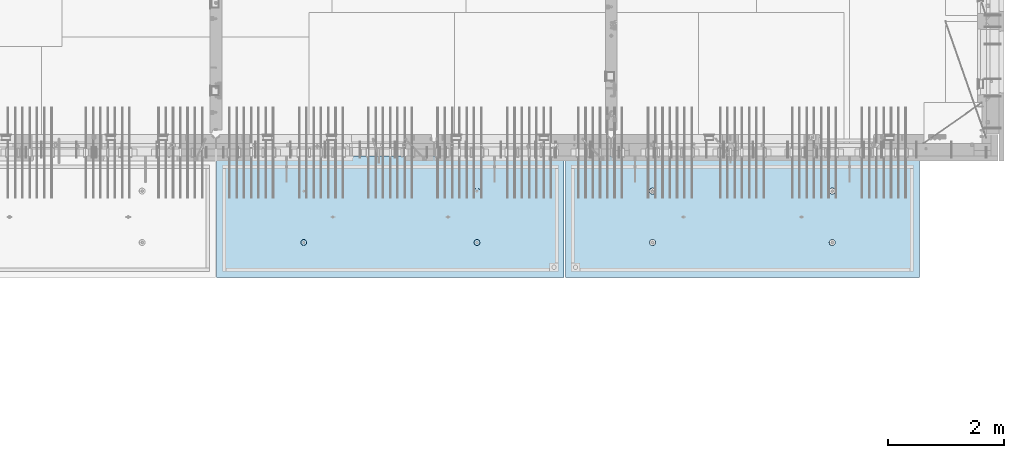
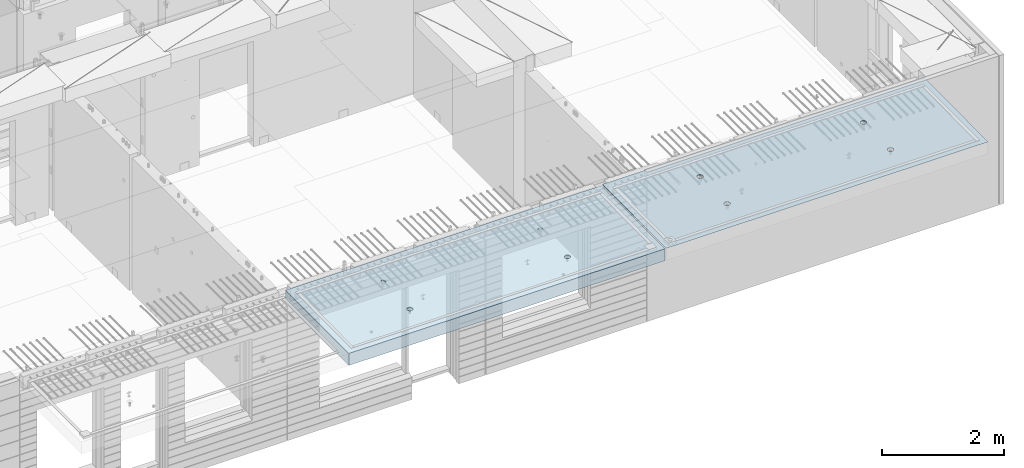
# One storey, part 203 of 350: 2 slabs, 2 elements without a shape of their own.
"""IFC2X3 building model written with IfcOpenShell, lengths in millimetres."""

from ifc_helpers import new_model, si_unit, frame, origin_with_axes, place, context, subcontext, project, spatial, faceted_brep, material, type_object, element, aggregate, save


model = new_model("IFC2X3")

# Units and contexts
model_context = context("Model", 3, precision=1e-05, world=origin_with_axes())
body_context = subcontext(model_context, "Body", "Model", "MODEL_VIEW")
ifc_project = project(units=[si_unit("LENGTHUNIT", "METRE", prefix="MILLI"), si_unit("AREAUNIT", "SQUARE_METRE"), si_unit("VOLUMEUNIT", "CUBIC_METRE"), si_unit("MASSUNIT", "GRAM", prefix="KILO"), si_unit("TIMEUNIT", "SECOND"), si_unit("PLANEANGLEUNIT", "RADIAN"), si_unit("SOLIDANGLEUNIT", "STERADIAN"), si_unit("THERMODYNAMICTEMPERATUREUNIT", "DEGREE_CELSIUS"), si_unit("LUMINOUSINTENSITYUNIT", "LUMEN")], contexts=[model_context])

# Site, building, storey
site_placement = place(None, origin_with_axes())
site = spatial("IfcSite", under=ifc_project, at=site_placement, CompositionType="ELEMENT")
building_placement = place(site_placement, origin_with_axes())
building = spatial("IfcBuilding", under=site, at=building_placement, CompositionType="ELEMENT")
storey_placement = place(building_placement, origin_with_axes())
storey = spatial("IfcBuildingStorey", under=building, at=storey_placement, Name="2", CompositionType="ELEMENT", Elevation=0.0)

# Assembly, slab
assembly_1_placement = place(storey_placement, origin_with_axes())
assembly_1 = element("IfcElementAssembly", 1, at=assembly_1_placement, inside=storey, AssemblyPlace="NOTDEFINED", PredefinedType="REINFORCEMENT_UNIT")
ifc_material = material(Name="CONCRETE/C35/45")
slab_type_1 = type_object("IfcSlabType", PredefinedType="NOTDEFINED")
slab_1_placement = place(assembly_1_placement, frame((33909.9998568133, 7629.99655735226, 87720.0), z_axis=(-1.11800000013248e-06, -0.999999999999375, 0.0), x_axis=(-0.999999999999093, 1.34699999998405e-06, 0.0)))
slab_1 = element("IfcSlab", 2, at=slab_1_placement, type_object=slab_type_1, material=ifc_material, PredefinedType="FLOOR", context=body_context, shape_type="Brep", body=[
    faceted_brep([(4540.5429407651, 4.39872694581572, 1501.06992058926), (4541.14829635528, 10.0, 1500.87322939105), (4548.44394652849, 10.0, 1515.19178906455), (4547.94177529477, 4.5376880098047, 1515.55663695519), (4559.80720044041, 10.0, 1526.55506865745), (4559.44971344555, 4.64790814399021, 1527.04710612474), (4574.1257436257, 10.0, 1533.85075119058), (4573.94028523447, 4.71864591048507, 1534.42153123348), (4589.99797731422, 10.0, 1536.36468442559), (4589.99797663917, 4.74301553473924, 1536.96206902392), (4605.87021668419, 10.0, 1533.85078706184), (4606.05567377324, 4.71864625823218, 1534.42156748629), (4620.18877635769, 10.0, 1526.55513688863), (4620.54626219634, 4.64790880566579, 1527.04717510301), (4631.55205595059, 10.0, 1515.19188297671), (4632.05422627598, 4.53768892097287, 1515.5567319414), (4638.84773848372, 10.0, 1500.87333979142), (4639.45309351355, 4.39872801757883, 1501.0700323201), (4641.36167171873, 10.0, 1485.0011061029), (4642.01569559209, 4.24458991442225, 1485.00110684195), (4638.84777435497, 10.0, 1469.12886673293), (4639.48645790269, 4.09034788147255, 1468.92134666652), (4631.55212418177, 10.0, 1454.81030705943), (4632.10822132771, 3.95111487063696, 1454.40627979329), (4620.18887026985, 10.0, 1443.44702746653), (4620.60028327593, 3.84055859092041, 1442.88076738872), (4605.87032708456, 10.0, 1436.1513449334), (4606.0891136727, 3.76954887632746, 1435.47799164192), (4589.99809339604, 10.0, 1433.63741169839), (4589.99809419923, 3.74507537655882, 1432.92662480936), (4574.12585402606, 10.0, 1436.15130906214), (4573.90706894744, 3.76954852712515, 1435.47795523847), (4559.80729435257, 10.0, 1443.44695923535), (4559.39588258188, 3.84055792690197, 1442.8806981667), (4548.44401475967, 10.0, 1454.81021314727), (4547.88791844284, 3.95111395715503, 1454.40618456334), (4541.14833222653, 10.0, 1469.12875633256), (4540.50964903182, 4.09034680826881, 1468.92123478504), (4538.63439899152, 10.0, 1485.00099002108), (4537.98037499001, 4.24458878673613, 1485.00098928203), (0.0, 10.0, 0.0), (0.0, -10.0, 0.0), (0.000819232023786753, 10.0, 2085.00366210937), (6090.0, 10.0, 1.39971234602854e-09), (6090.0, -10.0, 1.39971234602854e-09), (6090.0009765625, 10.0, 2085.00366210937), (1450.13343574908, -4.39996016312216, 583.805178487186), (1451.68970517172, 10.0, 584.310843019489), (1449.20358093267, 10.0, 600.007498901724), (1447.58488291994, -4.2445425120095, 600.007497072595), (1457.56794425657, -4.54025428339082, 569.17949076172), (1458.90468325205, 10.0, 570.15069079864), (1469.16362510388, -4.65165300057561, 557.566154097598), (1470.14226284945, 10.0, 558.913136598135), (1483.78541952188, -4.72320365252381, 550.106985529351), (1484.30243137612, 10.0, 551.698190519764), (1499.99909477071, -4.74786334385863, 547.536208193364), (1499.99909287695, 10.0, 549.212101755165), (1516.2127641972, -4.72320330067305, 550.107022210277), (1515.69574875919, 10.0, 551.698225994214), (1530.8345417251, -4.65165233150765, 557.566223847243), (1529.85590098004, 10.0, 558.913204074546), (1542.4301962863, -4.54025336292398, 569.179586717545), (1541.09345518054, 10.0, 570.150783671952), (1549.86467170747, -4.39995908172568, 583.805291221456), (1548.30840125891, 10.0, 584.310952198615), (1552.41318790712, -4.24454137573775, 600.00761552858), (1550.79449002351, 10.0, 600.007613699451), (1549.83105300624, -4.08922839167644, 616.199022553535), (1548.30836578447, 10.0, 615.704269581685), (1542.37578967018, -3.94920829200419, 630.796143582923), (1541.09338770413, 10.0, 629.864421802535), (1530.78010888273, -3.83814828256436, 642.374169903326), (1529.85580810672, 10.0, 641.101976003039), (1516.17906941009, -3.76687165064504, 649.804771831361), (1515.69563958006, 10.0, 648.316922081409), (1499.99897631459, -3.74231662515376, 652.364637735232), (1499.99897807923, 10.0, 650.803010846011), (1483.81888899212, -3.76687200104061, 649.804735302227), (1484.30232219699, 10.0, 648.316886606961), (1469.21786628045, -3.83814894927491, 642.374100399286), (1470.14216997614, 10.0, 641.101908526629), (1457.62221161949, -3.94920921009907, 630.796047872702), (1458.90461577564, 10.0, 629.864328929222), (1450.16698124064, -4.08922947161773, 616.198909971055), (1451.68966969727, 10.0, 615.704160402559), (1450.509655854, 4.09040925785666, 1468.92774521603), (1451.1483322995, 10.0, 1469.13526457059), (1448.63439906449, 10.0, 1485.00749825911), (1447.98038215714, 4.24465121529647, 1485.00749752007), (1457.88792425878, 3.95117642574769, 1454.41269697389), (1458.44401483263, 10.0, 1454.8167213853), (1469.39588682837, 3.84062041057041, 1442.8872121491), (1469.80729442553, 10.0, 1443.45346747338), (1483.90707121489, 3.76961102048517, 1435.48447023045), (1484.12585409903, 10.0, 1436.15781730018), (1499.99809427218, 3.74513787325122, 1432.93314014929), (1499.998093469, 10.0, 1433.64391993642), (1516.08911155117, 3.76961136968748, 1435.48450663389), (1515.87032715752, 10.0, 1436.15785317143), (1530.60027917537, 3.8406210745743, 1442.88728137111), (1530.18887034281, 10.0, 1443.45353570456), (1542.1082156577, 3.95117733922962, 1454.41279220383), (1541.55212425473, 10.0, 1454.81681529746), (1549.48645122644, 4.09041033107496, 1468.92785709749), (1548.84777442794, 10.0, 1469.13537497096), (1552.0156885709, 4.24465234298259, 1485.00761507997), (1551.3616717917, 10.0, 1485.00761434093), (1549.45308684185, 4.39879042512621, 1501.07653836665), (1548.84773855669, 10.0, 1500.87984802946), (1542.05422061333, 4.5377513095591, 1515.56323601226), (1541.55205602355, 10.0, 1515.19839121474), (1530.54625810314, 4.64797117923445, 1527.0536776068), (1530.18877643065, 10.0, 1526.56164512666), (1516.05567165627, 4.71870862215292, 1534.42806898436), (1515.87021675715, 10.0, 1533.85729529987), (1499.99797671215, 4.74307789534214, 1536.96857017552), (1499.99797738718, 10.0, 1536.37119266363), (1483.94028749739, 4.71870827439125, 1534.42803273156), (1484.12574369866, 10.0, 1533.85725942862), (1469.44971768469, 4.64797051755886, 1527.05360862854), (1469.80720051337, 10.0, 1526.56157689548), (1457.94178110336, 4.53775039840548, 1515.56314102606), (1458.44394660145, 10.0, 1515.19829730258), (1450.54294758273, 4.39878935334855, 1501.07642663582), (1451.14829642825, 10.0, 1500.87973762909), (4619.85580803376, 10.0, 641.095467765007), (4620.78011297592, -3.83821065611846, 642.367667399533), (4606.17907152706, -3.76693401455123, 649.798270333285), (4605.6956395071, 10.0, 648.310413843377), (4631.09338763116, 10.0, 629.857913564502), (4632.37579533283, -3.94927068060497, 630.789639512066), (4638.30836571149, 10.0, 615.697761343654), (4639.83105967794, -4.08929079922382, 616.192516506986), (4640.79448995054, 10.0, 600.001105461418), (4642.4131949283, -4.24460380429809, 600.001107290555), (4638.30840118594, 10.0, 584.304443960583), (4639.86467838373, -4.40002153132809, 583.798780790478), (4631.09345510758, 10.0, 570.14427543392), (4632.43020195632, -4.54031583151664, 569.173074307006), (4619.85590090707, 10.0, 558.906695836514), (4620.83454582566, -4.65171481517609, 557.559709864858), (4605.69574868622, 10.0, 551.691717756181), (4606.21276631872, -4.72326579401852, 550.100507218302), (4589.99909280399, 10.0, 549.205593517132), (4589.99909469776, -4.74792584055103, 547.529692853434), (4574.30243130315, 10.0, 551.691682281732), (4573.78541725442, -4.72326614588383, 550.10047053737), (4560.14226277649, 10.0, 558.906628360102), (4559.16362085739, -4.65171548424405, 557.559640115202), (4548.90468317908, 10.0, 570.144182560607), (4547.56793844064, -4.54031675198348, 569.172978351166), (4541.68970509875, 10.0, 584.304334781456), (4540.1334289269, -4.40002261272457, 583.798668056191), (4547.6222058109, -3.9492715986853, 630.789543801832), (4559.21786204131, -3.83821132282901, 642.367597895483), (4573.8188867292, -3.76693436496134, 649.798233804147), (4589.99897624161, -3.74237898574211, 652.358136583629), (4537.58487575281, -4.2446049405844, 600.000988834554), (4540.166974423, -4.0892918791651, 616.192403924491), (4589.99897800626, 10.0, 650.796502607977), (4574.30232212402, 10.0, 648.310378368928), (4560.14216990317, 10.0, 641.095400288596), (4548.90461570267, 10.0, 629.85782069119), (4541.6896696243, 10.0, 615.697652164527), (4539.2035808597, 10.0, 600.000990663691)], [[[0, 1, 2, 3]], [[3, 2, 4, 5]], [[5, 4, 6, 7]], [[8, 9, 7, 6]], [[10, 11, 9, 8]], [[12, 13, 11, 10]], [[14, 15, 13, 12]], [[16, 17, 15, 14]], [[18, 19, 17, 16]], [[20, 21, 19, 18]], [[22, 23, 21, 20]], [[24, 25, 23, 22]], [[25, 24, 26, 27]], [[27, 26, 28, 29]], [[29, 28, 30, 31]], [[31, 30, 32, 33]], [[33, 32, 34, 35]], [[35, 34, 36, 37]], [[37, 36, 38, 39]], [[39, 38, 1, 0]], [[40, 41, 42]], [[40, 43, 44, 41]], [[43, 45, 44]], [[46, 47, 48, 49]], [[50, 51, 47, 46]], [[52, 53, 51, 50]], [[54, 55, 53, 52]], [[56, 57, 55, 54]], [[58, 59, 57, 56]], [[59, 58, 60, 61]], [[61, 60, 62, 63]], [[63, 62, 64, 65]], [[65, 64, 66, 67]], [[67, 66, 68, 69]], [[69, 68, 70, 71]], [[71, 70, 72, 73]], [[73, 72, 74, 75]], [[75, 74, 76, 77]], [[78, 79, 77, 76]], [[80, 81, 79, 78]], [[82, 83, 81, 80]], [[84, 85, 83, 82]], [[49, 48, 85, 84]], [[86, 87, 88, 89]], [[90, 91, 87, 86]], [[92, 93, 91, 90]], [[94, 95, 93, 92]], [[96, 97, 95, 94]], [[98, 99, 97, 96]], [[100, 101, 99, 98]], [[101, 100, 102, 103]], [[103, 102, 104, 105]], [[105, 104, 106, 107]], [[107, 106, 108, 109]], [[109, 108, 110, 111]], [[111, 110, 112, 113]], [[113, 112, 114, 115]], [[115, 114, 116, 117]], [[117, 116, 118, 119]], [[120, 121, 119, 118]], [[122, 123, 121, 120]], [[124, 125, 123, 122]], [[89, 88, 125, 124]], [[126, 127, 128, 129]], [[130, 131, 127, 126]], [[132, 133, 131, 130]], [[134, 135, 133, 132]], [[136, 137, 135, 134]], [[138, 139, 137, 136]], [[140, 141, 139, 138]], [[142, 143, 141, 140]], [[143, 142, 144, 145]], [[145, 144, 146, 147]], [[147, 146, 148, 149]], [[149, 148, 150, 151]], [[151, 150, 152, 153]], [[41, 44, 45, 42], [3, 5, 7, 9, 11, 13, 15, 17, 19, 21, 23, 25, 27, 29, 31, 33, 35, 37, 39, 0], [154, 155, 156, 157, 128, 127, 131, 133, 135, 137, 139, 141, 143, 145, 147, 149, 151, 153, 158, 159], [122, 120, 118, 116, 114, 112, 110, 108, 106, 104, 102, 100, 98, 96, 94, 92, 90, 86, 89, 124], [82, 80, 78, 76, 74, 72, 70, 68, 66, 64, 62, 60, 58, 56, 54, 52, 50, 46, 49, 84]], [[129, 128, 157, 160]], [[156, 161, 160, 157]], [[155, 162, 161, 156]], [[154, 163, 162, 155]], [[159, 164, 163, 154]], [[158, 165, 164, 159]], [[153, 152, 165, 158]], [[43, 40, 42, 45], [34, 32, 30, 28, 26, 24, 22, 20, 18, 16, 14, 12, 10, 8, 6, 4, 2, 1, 38, 36], [150, 148, 146, 144, 142, 140, 138, 136, 134, 132, 130, 126, 129, 160, 161, 162, 163, 164, 165, 152], [91, 93, 95, 97, 99, 101, 103, 105, 107, 109, 111, 113, 115, 117, 119, 121, 123, 125, 88, 87], [51, 53, 55, 57, 59, 61, 63, 65, 67, 69, 71, 73, 75, 77, 79, 81, 83, 85, 48, 47]]]),
])
aggregate(assembly_1, [slab_1])

assembly_2_placement = place(storey_placement, origin_with_axes())
assembly_2 = element("IfcElementAssembly", 3, at=assembly_2_placement, inside=storey, AssemblyPlace="NOTDEFINED", PredefinedType="REINFORCEMENT_UNIT")
slab_type_2 = type_object("IfcSlabType", PredefinedType="NOTDEFINED")
slab_2_placement = place(assembly_2_placement, frame((27799.9998568133, 7629.99655735226, 87590.0), z_axis=(-1.11800000013248e-06, -0.999999999999375, 0.0), x_axis=(-0.999999999999093, 1.34699999998405e-06, 0.0)))
slab_2 = element("IfcSlab", 4, at=slab_2_placement, type_object=slab_type_2, material=ifc_material, PredefinedType="FLOOR", context=body_context, shape_type="Brep", body=[
    faceted_brep([(4464.54840508898, -115.0, 647.555217913627), (4450.61000036748, -115.0, 640.453225774507), (4439.54842599525, -115.0, 629.391625938503), (4432.44646594236, -115.0, 615.453204868262), (4429.99930954105, -115.0, 600.002352332828), (4432.44650151022, -115.0, 584.551505430789), (4439.54849364933, -115.0, 570.613100709295), (4450.61009348534, -115.0, 559.551526337066), (4464.54851455558, -115.0, 552.449566284174), (4479.99936709102, -115.0, 550.002409882861), (4495.45021399306, -115.0, 552.449601852029), (4509.38861871455, -115.0, 559.551593991148), (4520.45019308678, -115.0, 570.613193827152), (4527.55215313967, -115.0, 584.551614897394), (4529.99930954098, -115.0, 600.002467432828), (4527.55211757181, -115.0, 615.453314334867), (4520.4501254327, -115.0, 629.39171905636), (4509.38852559669, -115.0, 640.453293428589), (4495.45010452645, -115.0, 647.555253481482), (4479.99925199102, -115.0, 650.002409882794), (4439.08882528693, -120.0, 570.279131286869), (4431.90612869169, -120.0, 584.375926971106), (4450.27612512107, -120.0, 559.091857205865), (4464.37293733984, -120.0, 551.909193061462), (4479.99936774499, -120.0, 549.43422806468), (4495.62579245274, -120.0, 551.909229033498), (4509.72258813697, -120.0, 559.091925628744), (4520.90986221798, -120.0, 570.279225462882), (4528.09252636238, -120.0, 584.37603768165), (4530.56749135916, -120.0, 600.002468086805), (4528.09249039035, -120.0, 615.628892794549), (4520.9097937951, -120.0, 629.725688478787), (4509.72249396096, -120.0, 640.912962559792), (4495.6256817422, -120.0, 648.095626704194), (4479.99925133704, -120.0, 650.570591700976), (4464.3728266293, -120.0, 648.095590732158), (4450.27603094506, -120.0, 640.912894136913), (4439.08875686405, -120.0, 629.725594302773), (4431.90609271965, -120.0, 615.628782084005), (4429.43112772287, -120.0, 600.002351678851), (0.000819232023786753, -120.0, 2085.00366210938), (5980.0009765625, -120.0, 2085.00366210937), (5980.0009765625, 120.0, 2085.00366210937), (0.000819232023786753, 120.0, 2085.00366210938), (5980.0, -120.0, -2.4019755073823e-09), (5980.0, 120.0, -2.4019755073823e-09), (-7.27595761418343e-12, -120.0, -9.09494701772928e-13), (-7.27595761418343e-12, 120.0, -9.09494701772928e-13), (1515.44890870648, -105.0, 1437.44477976918), (1529.38731342797, -105.0, 1444.5467719083), (1540.4488878002, -105.0, 1455.60837174431), (1547.55084785309, -105.0, 1469.54679281455), (1549.99800425441, -105.0, 1484.99764534998), (1547.55081228524, -105.0, 1500.44849225202), (1540.44882014612, -105.0, 1514.38689697351), (1529.38722031012, -105.0, 1525.44847134574), (1515.44879923988, -105.0, 1532.55043139864), (1499.99794670444, -105.0, 1534.99758779995), (1484.5470998024, -105.0, 1532.55039583078), (1470.60869508091, -105.0, 1525.44840369166), (1459.54712070868, -105.0, 1514.38680385566), (1452.44516065579, -105.0, 1500.44838278542), (1449.99800425447, -105.0, 1484.99753024998), (1452.44519622364, -105.0, 1469.54668334794), (1459.54718836276, -105.0, 1455.60827862645), (1470.60878819877, -105.0, 1444.54670425422), (1484.547209269, -105.0, 1437.44474420133), (1499.99806180444, -105.0, 1434.99758780001), (1450.82407776805, -120.0, 1469.01994796889), (1448.29345879993, -120.0, 1484.99752828805), (1458.16818327555, -120.0, 1454.60637035917), (1469.60688310596, -120.0, 1443.16769686061), (1484.02047762178, -120.0, 1435.82362453319), (1499.99806376637, -120.0, 1433.29304234547), (1515.97564408552, -120.0, 1435.82366131359), (1530.38922169525, -120.0, 1443.16776682109), (1541.82789519381, -120.0, 1454.6064666515), (1549.17196752123, -120.0, 1469.02006116732), (1551.70254970895, -120.0, 1484.99764731191), (1549.17193074083, -120.0, 1500.97522763107), (1541.82782523334, -120.0, 1515.38880524079), (1530.38912540293, -120.0, 1526.82747873935), (1515.9755308871, -120.0, 1534.17155106677), (1499.99794474251, -120.0, 1536.70213325449), (1484.02036442336, -120.0, 1534.17151428637), (1469.60678681363, -120.0, 1526.82740877888), (1458.16811331507, -120.0, 1515.38870894846), (1450.82404098765, -120.0, 1500.97511443265), (1484.54840517324, -115.0, 647.55178787166), (1470.61000045175, -115.0, 640.44979573254), (1459.54842607952, -115.0, 629.388195896537), (1452.44646602663, -115.0, 615.449774826296), (1449.99930962532, -115.0, 599.998922290862), (1452.44650159449, -115.0, 584.548075388822), (1459.5484937336, -115.0, 570.609670667329), (1470.61009356961, -115.0, 559.5480962951), (1484.54851463985, -115.0, 552.446136242207), (1499.99936717528, -115.0, 549.998979840894), (1515.45021407733, -115.0, 552.446171810063), (1529.38861879882, -115.0, 559.548163949182), (1540.45019317105, -115.0, 570.609763785185), (1547.55215322394, -115.0, 584.548184855427), (1549.99930962525, -115.0, 599.999037390861), (1547.55211765608, -115.0, 615.449884292901), (1540.45012551697, -115.0, 629.388289014393), (1529.38852568096, -115.0, 640.449863386622), (1515.45010461072, -115.0, 647.551823439516), (1499.99925207528, -115.0, 649.998979840828), (1451.90612877595, -120.0, 584.37249692914), (1449.43112780714, -120.0, 599.998921636884), (1459.0888253712, -120.0, 570.275701244902), (1470.27612520534, -120.0, 559.088427163899), (1484.3729374241, -120.0, 551.905763019496), (1499.99936782926, -120.0, 549.430798022713), (1515.62579253701, -120.0, 551.905798991532), (1529.72258822124, -120.0, 559.088495586778), (1540.90986230225, -120.0, 570.275795420916), (1548.09252644665, -120.0, 584.372607639683), (1550.56749144343, -120.0, 599.999038044839), (1548.09249047462, -120.0, 615.625462752582), (1540.90979387937, -120.0, 629.72225843682), (1529.72249404523, -120.0, 640.909532517825), (1515.62568182647, -120.0, 648.092196662227), (1499.9992514213, -120.0, 650.56716165901), (1484.37282671356, -120.0, 648.092160690191), (1470.27603102933, -120.0, 640.909464094946), (1459.08875694832, -120.0, 629.722164260806), (1451.90609280392, -120.0, 615.625352042039), (4495.44890862221, -105.0, 1437.44820981115), (4509.3873133437, -105.0, 1444.55020195027), (4520.44888771593, -105.0, 1455.61180178627), (4527.55084776882, -105.0, 1469.55022285651), (4529.99800417014, -105.0, 1485.00107539195), (4527.55081220097, -105.0, 1500.45192229399), (4520.44882006185, -105.0, 1514.39032701548), (4509.38722022585, -105.0, 1525.45190138771), (4495.44879915561, -105.0, 1532.5538614406), (4479.99794662017, -105.0, 1535.00101784192), (4464.54709971813, -105.0, 1532.55382587275), (4450.60869499664, -105.0, 1525.45183373363), (4439.54712062441, -105.0, 1514.39023389763), (4432.44516057152, -105.0, 1500.45181282738), (4429.9980041702, -105.0, 1485.00096029195), (4432.44519613937, -105.0, 1469.55011338991), (4439.54718827849, -105.0, 1455.61170866842), (4450.6087881145, -105.0, 1444.55013429619), (4464.54720918474, -105.0, 1437.44817424329), (4479.99806172017, -105.0, 1435.00101784198), (4430.82407768378, -120.0, 1469.02337801086), (4428.29345871566, -120.0, 1485.00095833002), (4438.16818319128, -120.0, 1454.60980040114), (4449.60688302169, -120.0, 1443.17112690258), (4464.02047753751, -120.0, 1435.82705457516), (4479.99806368211, -120.0, 1433.29647238744), (4495.97564400126, -120.0, 1435.82709135556), (4510.38922161098, -120.0, 1443.17119686305), (4521.82789510954, -120.0, 1454.60989669347), (4529.17196743696, -120.0, 1469.02349120928), (4531.70254962468, -120.0, 1485.00107735388), (4529.17193065656, -120.0, 1500.97865767303), (4521.82782514907, -120.0, 1515.39223528276), (4510.38912531866, -120.0, 1526.83090878132), (4495.97553080284, -120.0, 1534.17498110874), (4479.99794465824, -120.0, 1536.70556329646), (4464.02036433909, -120.0, 1534.17494432834), (4449.60678672936, -120.0, 1526.83083882084), (4438.1681132308, -120.0, 1515.39213899043), (4430.82404090338, -120.0, 1500.97854447461)], [[[0, 1, 2, 3, 4, 5, 6, 7, 8, 9, 10, 11, 12, 13, 14, 15, 16, 17, 18, 19]], [[20, 6, 5, 21]], [[22, 7, 6, 20]], [[23, 8, 7, 22]], [[24, 9, 8, 23]], [[25, 10, 9, 24]], [[26, 11, 10, 25]], [[27, 12, 11, 26]], [[28, 13, 12, 27]], [[29, 14, 13, 28]], [[30, 15, 14, 29]], [[31, 16, 15, 30]], [[32, 17, 16, 31]], [[33, 18, 17, 32]], [[34, 19, 18, 33]], [[35, 0, 19, 34]], [[36, 1, 0, 35]], [[37, 2, 1, 36]], [[38, 3, 2, 37]], [[39, 4, 3, 38]], [[21, 5, 4, 39]], [[40, 41, 42, 43]], [[41, 44, 45, 42]], [[44, 46, 47, 45]], [[42, 45, 47, 43]], [[46, 40, 43, 47]], [[48, 49, 50, 51, 52, 53, 54, 55, 56, 57, 58, 59, 60, 61, 62, 63, 64, 65, 66, 67]], [[68, 63, 62, 69]], [[70, 64, 63, 68]], [[71, 65, 64, 70]], [[72, 66, 65, 71]], [[73, 67, 66, 72]], [[74, 48, 67, 73]], [[75, 49, 48, 74]], [[76, 50, 49, 75]], [[77, 51, 50, 76]], [[78, 52, 51, 77]], [[79, 53, 52, 78]], [[80, 54, 53, 79]], [[81, 55, 54, 80]], [[82, 56, 55, 81]], [[83, 57, 56, 82]], [[84, 58, 57, 83]], [[85, 59, 58, 84]], [[86, 60, 59, 85]], [[87, 61, 60, 86]], [[69, 62, 61, 87]], [[88, 89, 90, 91, 92, 93, 94, 95, 96, 97, 98, 99, 100, 101, 102, 103, 104, 105, 106, 107]], [[108, 93, 92, 109]], [[110, 94, 93, 108]], [[111, 95, 94, 110]], [[112, 96, 95, 111]], [[113, 97, 96, 112]], [[114, 98, 97, 113]], [[115, 99, 98, 114]], [[116, 100, 99, 115]], [[117, 101, 100, 116]], [[118, 102, 101, 117]], [[119, 103, 102, 118]], [[120, 104, 103, 119]], [[121, 105, 104, 120]], [[122, 106, 105, 121]], [[123, 107, 106, 122]], [[124, 88, 107, 123]], [[125, 89, 88, 124]], [[126, 90, 89, 125]], [[127, 91, 90, 126]], [[109, 92, 91, 127]], [[128, 129, 130, 131, 132, 133, 134, 135, 136, 137, 138, 139, 140, 141, 142, 143, 144, 145, 146, 147]], [[148, 143, 142, 149]], [[150, 144, 143, 148]], [[151, 145, 144, 150]], [[152, 146, 145, 151]], [[153, 147, 146, 152]], [[154, 128, 147, 153]], [[155, 129, 128, 154]], [[156, 130, 129, 155]], [[157, 131, 130, 156]], [[158, 132, 131, 157]], [[159, 133, 132, 158]], [[160, 134, 133, 159]], [[161, 135, 134, 160]], [[162, 136, 135, 161]], [[163, 137, 136, 162]], [[164, 138, 137, 163]], [[165, 139, 138, 164]], [[166, 140, 139, 165]], [[167, 141, 140, 166]], [[149, 142, 141, 167]], [[44, 41, 40, 46], [37, 36, 35, 34, 33, 32, 31, 30, 29, 28, 27, 26, 25, 24, 23, 22, 20, 21, 39, 38], [166, 165, 164, 163, 162, 161, 160, 159, 158, 157, 156, 155, 154, 153, 152, 151, 150, 148, 149, 167], [126, 125, 124, 123, 122, 121, 120, 119, 118, 117, 116, 115, 114, 113, 112, 111, 110, 108, 109, 127], [86, 85, 84, 83, 82, 81, 80, 79, 78, 77, 76, 75, 74, 73, 72, 71, 70, 68, 69, 87]]]),
])
aggregate(assembly_2, [slab_2])

save(model, "model.ifc")
